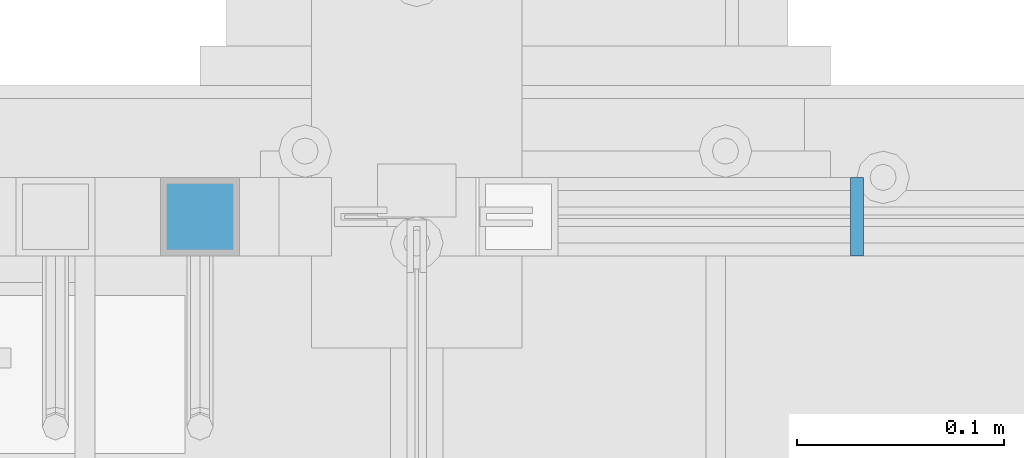
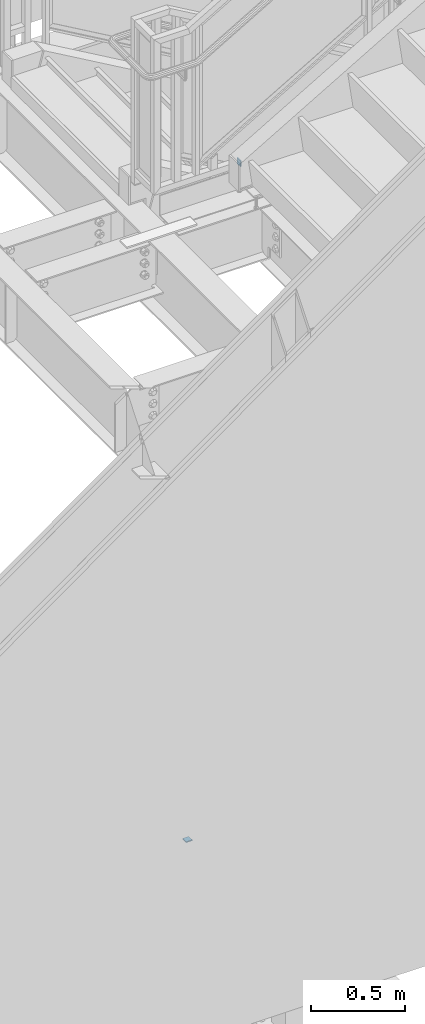
# One storey, part 965 of 1179: 2 beams, 2 elements without a shape of their own.
"""IFC2X3 building model written with IfcOpenShell, lengths in millimetres."""

from ifc_helpers import new_model, si_unit, frame, origin_with_axes, place, context, subcontext, project, spatial, faceted_brep, material, type_object, element, aggregate, save


model = new_model("IFC2X3")

# Units and contexts
model_context = context("Model", 3, precision=1e-05, world=origin_with_axes())
body_context = subcontext(model_context, "Body", "Model", "MODEL_VIEW")
ifc_project = project(units=[si_unit("LENGTHUNIT", "METRE", prefix="MILLI"), si_unit("AREAUNIT", "SQUARE_METRE"), si_unit("VOLUMEUNIT", "CUBIC_METRE"), si_unit("MASSUNIT", "GRAM", prefix="KILO"), si_unit("TIMEUNIT", "SECOND"), si_unit("PLANEANGLEUNIT", "RADIAN"), si_unit("SOLIDANGLEUNIT", "STERADIAN"), si_unit("THERMODYNAMICTEMPERATUREUNIT", "DEGREE_CELSIUS"), si_unit("LUMINOUSINTENSITYUNIT", "LUMEN")], contexts=[model_context])

# Site, building, storey
site_placement = place(None, origin_with_axes())
site = spatial("IfcSite", under=ifc_project, at=site_placement, CompositionType="ELEMENT")
building_placement = place(site_placement, origin_with_axes())
building = spatial("IfcBuilding", under=site, at=building_placement, Name="Undefined", CompositionType="ELEMENT")
storey_placement = place(building_placement, origin_with_axes())
storey = spatial("IfcBuildingStorey", under=building, at=storey_placement, Name="Undefined", CompositionType="ELEMENT", Elevation=0.0)

# Assembly, beam
assembly_1_placement = place(storey_placement, origin_with_axes())
assembly_1 = element("IfcElementAssembly", 1, at=assembly_1_placement, inside=storey, Name="GUARDRAIL", AssemblyPlace="NOTDEFINED", PredefinedType="RIGID_FRAME")
ifc_material = material(Name="STEEL/A36")
beam_type = type_object("IfcBeamType", PredefinedType="NOTDEFINED")
beam_1_placement = place(assembly_1_placement, frame((19818.3499998126, 39490.6499997377, 4330.699999235), z_axis=(0.0, 0.0, 1.0), x_axis=(0.0, -1.0, 0.0)))
beam_1 = element("IfcBeam", 2, at=beam_1_placement, type_object=beam_type, material=ifc_material, Name="PLATE", context=body_context, shape_type="Brep", body=[
    faceted_brep([(-3.63797880709171e-12, 3.17499999999927, -19.0500000000029), (-3.63797880709171e-12, 3.17499999999927, 19.0500000000029), (38.0999984699993, 3.17500000001564, 19.0500000000029), (38.0999984699993, 3.17500000001564, -19.0500000000029), (3.63797880709171e-12, -3.17500000000109, 19.0500000000029), (38.0999984700065, -3.17499999998472, 19.0500000000029), (3.63797880709171e-12, -3.17500000000109, -19.0500000000029), (38.0999984700065, -3.17499999998472, -19.0500000000029)], [[[0, 1, 2, 3]], [[1, 4, 5, 2]], [[4, 6, 7, 5]], [[6, 0, 3, 7]], [[5, 7, 3, 2]], [[6, 4, 1, 0]]]),
])
aggregate(assembly_1, [beam_1])

assembly_2_placement = place(storey_placement, origin_with_axes())
assembly_2 = element("IfcElementAssembly", 3, at=assembly_2_placement, inside=storey, Name="GUARDRAIL", AssemblyPlace="NOTDEFINED", PredefinedType="RIGID_FRAME")
beam_2_placement = place(assembly_2_placement, frame((19519.8999996493, 39471.5999999818, 44.0556392036358), z_axis=(0.0, -1.0, 0.0), x_axis=(-1.0, 0.0, 0.0)))
beam_2 = element("IfcBeam", 4, at=beam_2_placement, type_object=beam_type, material=ifc_material, Name="PLATE", context=body_context, shape_type="Brep", body=[
    faceted_brep([(-3.63797880709171e-12, 3.17499999999927, -19.0500000000029), (-3.63797880709171e-12, 3.17499999999927, 19.0500000000029), (38.0999984699993, 3.17500000001564, 19.0500000000029), (38.0999984699993, 3.17500000001564, -19.0500000000029), (3.63797880709171e-12, -3.17500000000109, 19.0500000000029), (38.0999984700065, -3.17499999998472, 19.0500000000029), (3.63797880709171e-12, -3.17500000000109, -19.0500000000029), (38.0999984700065, -3.17499999998472, -19.0500000000029)], [[[0, 1, 2, 3]], [[1, 4, 5, 2]], [[4, 6, 7, 5]], [[6, 0, 3, 7]], [[5, 7, 3, 2]], [[6, 4, 1, 0]]]),
])
aggregate(assembly_2, [beam_2])

save(model, "model.ifc")
